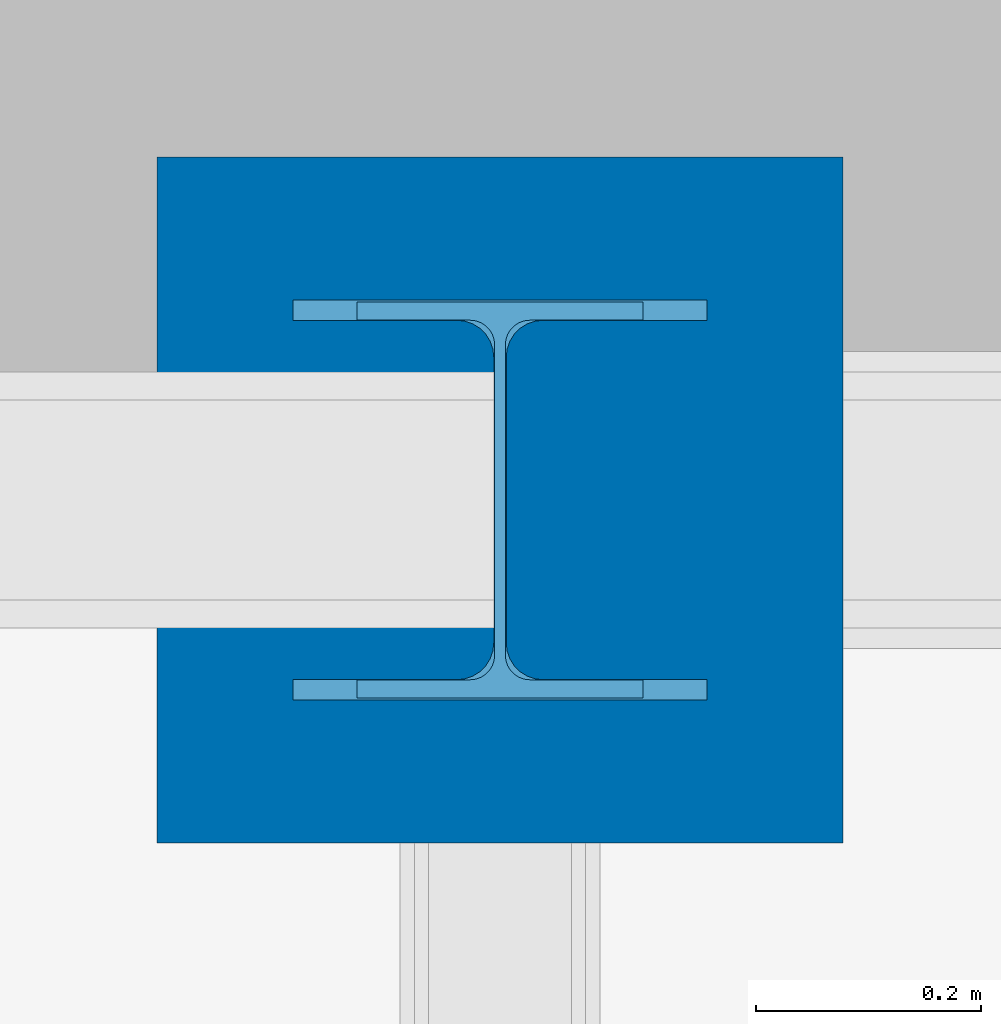
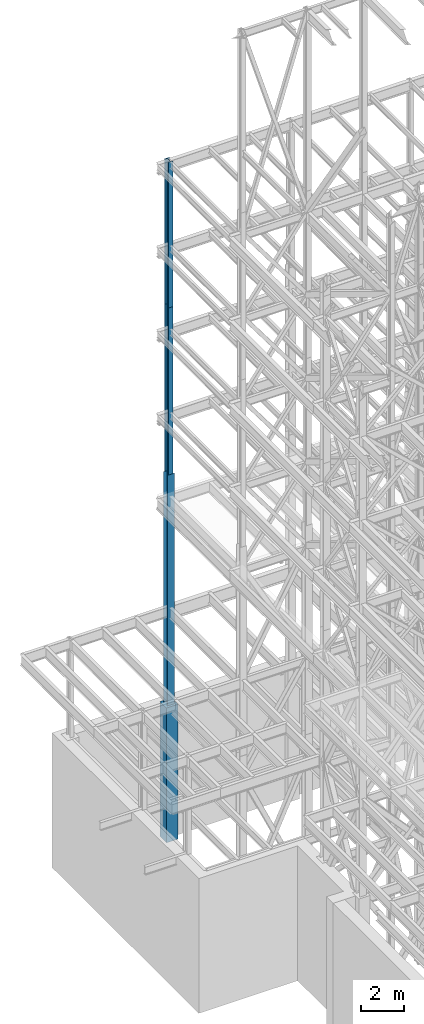
# One storey, part 53 of 150: 4 columns.
"""IFC2X3 building model written with IfcOpenShell, lengths in millimetres."""

from ifc_helpers import new_model, si_unit, frame, origin_with_axes, origin_2d_with_axis, place, context, subcontext, project, spatial, rectangle, i_section, extrude, material, type_object, element, save


model = new_model("IFC2X3")

# Units and contexts
model_context = context("Model", 3, precision=1e-05, world=origin_with_axes())
body_context = subcontext(model_context, "Body", "Model", "MODEL_VIEW")
ifc_project = project(units=[si_unit("LENGTHUNIT", "METRE", prefix="MILLI"), si_unit("AREAUNIT", "SQUARE_METRE"), si_unit("VOLUMEUNIT", "CUBIC_METRE"), si_unit("MASSUNIT", "GRAM", prefix="KILO"), si_unit("TIMEUNIT", "SECOND"), si_unit("PLANEANGLEUNIT", "RADIAN"), si_unit("SOLIDANGLEUNIT", "STERADIAN"), si_unit("THERMODYNAMICTEMPERATUREUNIT", "DEGREE_CELSIUS"), si_unit("LUMINOUSINTENSITYUNIT", "LUMEN")], contexts=[model_context])

# Site, building, storey
site_placement = place(None, origin_with_axes())
site = spatial("IfcSite", under=ifc_project, at=site_placement, CompositionType="ELEMENT")
building_placement = place(site_placement, origin_with_axes())
building = spatial("IfcBuilding", under=site, at=building_placement, Name="Undefined", CompositionType="ELEMENT")
storey_placement = place(building_placement, origin_with_axes())
storey = spatial("IfcBuildingStorey", under=building, at=storey_placement, Name="Undefined", CompositionType="ELEMENT", Elevation=0.0)

# Columns
ifc_material_1 = material(Name="STEEL/A992")
column_type_1 = type_object("IfcColumnType", Name="W14X61", PredefinedType="NOTDEFINED")
column_1_placement = place(storey_placement, frame((5283.2, 38862.0, 46253.4), z_axis=(0.0, 0.0, 1.0), x_axis=(1.0, 0.0, 0.0)))
element("IfcColumn", 1, at=column_1_placement, inside=storey, type_object=column_type_1, material=ifc_material_1, Name="COLUMN", ObjectType="W14X61", context=body_context, shape_type="SweptSolid", body=[
    extrude(i_section(OverallWidth=254.0, OverallDepth=352.425, WebThickness=9.5249, FlangeThickness=16.383, FilletRadius=21.717, at=origin_2d_with_axis()), frame((0.0, 0.0, 8229.60000000002), z_axis=(0.0, 0.0, -1.0), x_axis=(-1.0, 0.0, 0.0)), (0.0, 0.0, 1.0), 8229.60000000001),
])
column_2_placement = place(storey_placement, frame((5283.2, 38862.0, 36804.6012877801), z_axis=(0.0, 0.0, 1.0), x_axis=(1.0, 0.0, 0.0)))
element("IfcColumn", 2, at=column_2_placement, inside=storey, type_object=column_type_1, material=ifc_material_1, Name="COLUMN", ObjectType="W14X61", context=body_context, shape_type="SweptSolid", body=[
    extrude(i_section(OverallWidth=254.0, OverallDepth=352.425, WebThickness=9.5249, FlangeThickness=16.383, FilletRadius=21.717, at=origin_2d_with_axis()), frame((0.0, 0.0, 9448.79871221987), z_axis=(0.0, 0.0, -1.0), x_axis=(-1.0, 0.0, 0.0)), (0.0, 0.0, 1.0), 9448.79871221987),
])
column_type_2 = type_object("IfcColumnType", Name="W14X90", PredefinedType="NOTDEFINED")
column_3_placement = place(storey_placement, frame((5283.2, 38862.0, 22707.6), z_axis=(0.0, 0.0, 1.0), x_axis=(1.0, 0.0, 0.0)))
element("IfcColumn", 3, at=column_3_placement, inside=storey, type_object=column_type_2, material=ifc_material_1, Name="COLUMN", ObjectType="W14X90", context=body_context, shape_type="SweptSolid", body=[
    extrude(i_section(OverallWidth=368.3, OverallDepth=355.6, WebThickness=11.1125, FlangeThickness=18.034, FilletRadius=32.7659, at=origin_2d_with_axis()), frame((0.0, 0.0, 14097.0012877801), z_axis=(0.0, 0.0, -1.0), x_axis=(-1.0, 0.0, 0.0)), (0.0, 0.0, 1.0), 14097.0012877801),
])
ifc_material_2 = material(Name="CONCRETE/5000")
column_type_3 = type_object("IfcColumnType", PredefinedType="NOTDEFINED")
column_4_placement = place(storey_placement, frame((5283.2, 38862.0, 16154.4), z_axis=(0.0, 0.0, 1.0), x_axis=(1.0, 0.0, 0.0)))
element("IfcColumn", 4, at=column_4_placement, inside=storey, type_object=column_type_3, material=ifc_material_2, Name="COLUMN", context=body_context, shape_type="SweptSolid", body=[
    extrude(rectangle(XDim=609.6, YDim=609.6, at=origin_2d_with_axis()), frame((0.0, 0.0, 7620.0), z_axis=(0.0, 0.0, -1.0), x_axis=(0.0, -1.0, 0.0)), (0.0, 0.0, 1.0), 7620.0),
])

save(model, "model.ifc")
